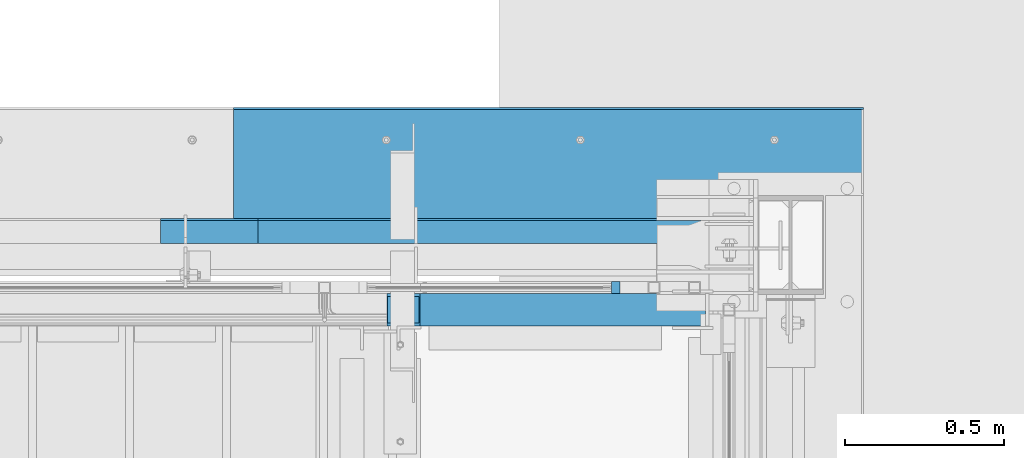
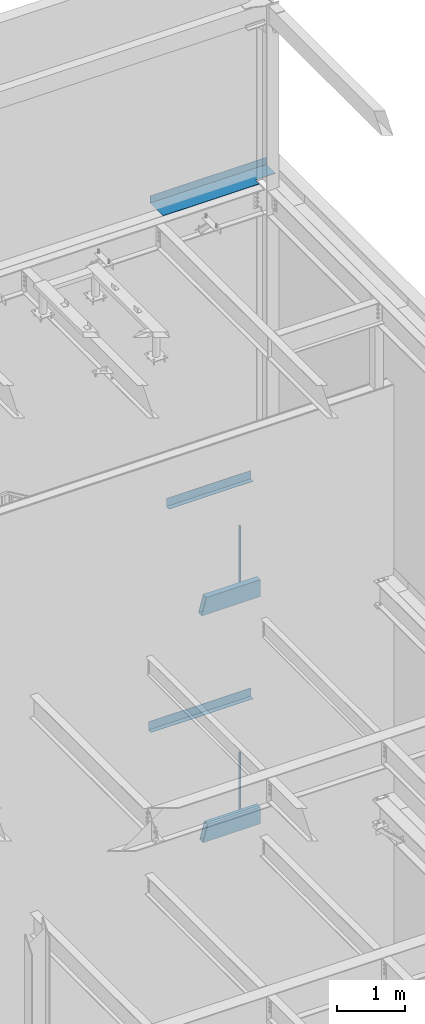
# One storey, part 800 of 1179: 5 beams, 2 members, 7 elements without a shape of their own.
"""IFC2X3 building model written with IfcOpenShell, lengths in millimetres."""

from ifc_helpers import new_model, si_unit, frame, origin_with_axes, place, context, subcontext, project, spatial, faceted_brep, material, type_object, element, aggregate, save


model = new_model("IFC2X3")

# Units and contexts
model_context = context("Model", 3, precision=1e-05, world=origin_with_axes())
body_context = subcontext(model_context, "Body", "Model", "MODEL_VIEW")
ifc_project = project(units=[si_unit("LENGTHUNIT", "METRE", prefix="MILLI"), si_unit("AREAUNIT", "SQUARE_METRE"), si_unit("VOLUMEUNIT", "CUBIC_METRE"), si_unit("MASSUNIT", "GRAM", prefix="KILO"), si_unit("TIMEUNIT", "SECOND"), si_unit("PLANEANGLEUNIT", "RADIAN"), si_unit("SOLIDANGLEUNIT", "STERADIAN"), si_unit("THERMODYNAMICTEMPERATUREUNIT", "DEGREE_CELSIUS"), si_unit("LUMINOUSINTENSITYUNIT", "LUMEN")], contexts=[model_context])

# Site, building, storey
site_placement = place(None, origin_with_axes())
site = spatial("IfcSite", under=ifc_project, at=site_placement, CompositionType="ELEMENT")
building_placement = place(site_placement, origin_with_axes())
building = spatial("IfcBuilding", under=site, at=building_placement, Name="Undefined", CompositionType="ELEMENT")
storey_placement = place(building_placement, origin_with_axes())
storey = spatial("IfcBuildingStorey", under=building, at=storey_placement, Name="Undefined", CompositionType="ELEMENT", Elevation=0.0)

# Assembly, member
assembly_1_placement = place(storey_placement, origin_with_axes())
assembly_1 = element("IfcElementAssembly", 1, at=assembly_1_placement, inside=storey, Name="GUARDRAIL", AssemblyPlace="NOTDEFINED", PredefinedType="RIGID_FRAME")
ifc_material_1 = material(Name="STEEL/A36")
member_type = type_object("IfcMemberType", PredefinedType="NOTDEFINED")
member_1_placement = place(assembly_1_placement, frame((23758.5250029074, 41065.4499993604, 1952.62499991228), z_axis=(0.0, -1.0, 0.0), x_axis=(0.0, 0.0, 1.0)))
member_1 = element("IfcMember", 2, at=member_1_placement, type_object=member_type, material=ifc_material_1, Name="POST", context=body_context, shape_type="Brep", body=[
    faceted_brep([(0.0, 12.7000000000007, -19.0500000000029), (0.0, 12.7000000000007, 19.0500000000029), (1212.8500000288, 12.7000000000007, 19.0500000000029), (1212.8500000288, 12.7000000000007, -19.0500000000029), (0.0, -12.7000000000007, 19.0500000000029), (1212.8500000288, -12.7000000000007, 19.0500000000029), (0.0, -12.7000000000007, -19.0500000000029), (1212.8500000288, -12.7000000000007, -19.0500000000029)], [[[0, 1, 2, 3]], [[1, 4, 5, 2]], [[4, 6, 7, 5]], [[6, 0, 3, 7]], [[5, 7, 3, 2]], [[6, 4, 1, 0]]]),
])
aggregate(assembly_1, [member_1])

assembly_2_placement = place(storey_placement, origin_with_axes())
assembly_2 = element("IfcElementAssembly", 3, at=assembly_2_placement, inside=storey, Name="GUARDRAIL", AssemblyPlace="NOTDEFINED", PredefinedType="RIGID_FRAME")
member_2_placement = place(assembly_2_placement, frame((23758.525002295, 41065.449999238, 6038.85000001208), z_axis=(0.0, -1.0, 0.0), x_axis=(0.0, 0.0, 1.0)))
member_2 = element("IfcMember", 4, at=member_2_placement, type_object=member_type, material=ifc_material_1, Name="POST", context=body_context, shape_type="Brep", body=[
    faceted_brep([(0.0, 12.7000000000007, -19.0500000000029), (0.0, 12.7000000000007, 19.0500000000029), (1200.14999994157, 12.7000000000007, 19.0500000000029), (1200.14999994157, 12.7000000000007, -19.0500000000029), (0.0, -12.7000000000007, 19.0500000000029), (1200.14999994157, -12.7000000000007, 19.0500000000029), (0.0, -12.7000000000007, -19.0500000000029), (1200.14999994157, -12.7000000000007, -19.0500000000029)], [[[0, 1, 2, 3]], [[1, 4, 5, 2]], [[4, 6, 7, 5]], [[6, 0, 3, 7]], [[5, 7, 3, 2]], [[6, 4, 1, 0]]]),
])
aggregate(assembly_2, [member_2])

# Assembly, beam
assembly_3_placement = place(storey_placement, origin_with_axes())
assembly_3 = element("IfcElementAssembly", 5, at=assembly_3_placement, inside=storey, Name="BEAM", AssemblyPlace="NOTDEFINED", PredefinedType="RIGID_FRAME")
beam_type_1 = type_object("IfcBeamType", PredefinedType="NOTDEFINED")
beam_1_placement = place(assembly_3_placement, frame((23198.9307500839, 41204.3562815049, 3933.82500614879), z_axis=(-1.0, 0.0, 0.0), x_axis=(0.0, 1.0, 0.0)))
beam_1 = element("IfcBeam", 6, at=beam_1_placement, type_object=beam_type_1, material=ifc_material_1, Name="BENT_PLATE", context=body_context, shape_type="Brep", body=[
    faceted_brep([(2.22644302994013e-09, -3.17500000000064, -869.950000000001), (-6.76664058119059e-10, -3.17500000000064, 869.950000000001), (-2.23371898755431e-09, 3.17499999999973, 869.950000000001), (6.69388100504875e-10, 3.17499999999973, -869.950000000001), (78.5812123482465, 3.17500001945837, 869.949999999844), (78.5812123494979, 3.17500001945837, -869.950000000154), (72.231211854174, -3.1749999821136, -869.950000000143), (72.2312118529226, -3.1749999821136, 869.949999999859), (78.5812004597101, -149.224999946321, 869.949999999702), (78.5812004625259, -149.224999944689, -869.950000000295), (72.2312004597043, -149.224999451009, 869.949999999717), (72.2312004625201, -149.224999449377, -869.950000000284)], [[[0, 1, 2, 3]], [[3, 2, 4, 5]], [[1, 0, 6, 7]], [[5, 4, 8, 9]], [[4, 2, 1, 7, 10, 8]], [[7, 6, 11, 10]], [[6, 0, 3, 5, 9, 11]], [[10, 11, 9, 8]]]),
])
aggregate(assembly_3, [beam_1])

assembly_4_placement = place(storey_placement, origin_with_axes())
assembly_4 = element("IfcElementAssembly", 7, at=assembly_4_placement, inside=storey, Name="BEAM", AssemblyPlace="NOTDEFINED", PredefinedType="RIGID_FRAME")
beam_2_placement = place(assembly_4_placement, frame((23351.3310000839, 41204.3562812314, 7845.42500614864), z_axis=(-1.0, 0.0, 0.0), x_axis=(0.0, 1.0, 0.0)))
beam_2 = element("IfcBeam", 8, at=beam_2_placement, type_object=beam_type_1, material=ifc_material_1, Name="BENT_PLATE", context=body_context, shape_type="Brep", body=[
    faceted_brep([(1.97178451344371e-09, -3.17500000000018, -716.7565), (-4.22005541622639e-10, -3.17500000000018, 716.7565), (-1.97906047105789e-09, 3.17500000000018, 716.7565), (4.14729584008455e-10, 3.17500000000018, -716.7565), (78.5812123420474, 3.17500001945882, 716.756499999847), (78.5812123430806, 3.17500001945882, -716.756500000156), (72.2312118477494, -3.17499998211406, -716.756500000141), (72.2312118467235, -3.17499998211406, 716.756499999858), (78.5812004536492, -149.224999952477, 716.756499999701), (78.581200455963, -149.224999951132, -716.756500000298), (72.2312004536507, -149.224999457165, 716.756499999716), (72.2312004559644, -149.224999455821, -716.756500000283)], [[[0, 1, 2, 3]], [[3, 2, 4, 5]], [[1, 0, 6, 7]], [[5, 4, 8, 9]], [[4, 2, 1, 7, 10, 8]], [[7, 6, 11, 10]], [[6, 0, 3, 5, 9, 11]], [[10, 11, 9, 8]]]),
])
aggregate(assembly_4, [beam_2])

assembly_5_placement = place(storey_placement, origin_with_axes())
assembly_5 = element("IfcElementAssembly", 9, at=assembly_5_placement, inside=storey, Name="BEAM", AssemblyPlace="NOTDEFINED", PredefinedType="RIGID_FRAME")
beam_type_2 = type_object("IfcBeamType", PredefinedType="NOTDEFINED")
beam_3_placement = place(assembly_5_placement, frame((23547.3874999922, 41244.8379999322, 13122.275), z_axis=(-1.0, 0.0, 0.0), x_axis=(0.0, 1.0, 0.0)))
beam_3 = element("IfcBeam", 10, at=beam_3_placement, type_object=beam_type_2, material=ifc_material_1, Name="BENT_PLATE", context=body_context, shape_type="Brep", body=[
    faceted_brep([(115.887000067814, -3.17499999999927, -644.525000007776), (115.887000067814, 3.17499999999927, -644.525000007776), (115.887000067814, 3.17499999999927, -989.012500000001), (115.887000067814, -3.17499999999927, -989.012500000001), (0.0, -3.17499999999927, -644.525000007776), (0.0, 3.17499999999927, -644.525000007776), (385.761999997871, 3.17499999999927, 989.0125), (0.0, 3.17499999999927, 989.0125), (0.0, -3.17499999999927, 989.0125), (379.411999997865, -3.17499999999927, 989.0125), (379.411999997865, -130.17500000214, 989.0125), (385.761999997871, -130.17500000214, 989.0125), (385.761999997871, 3.17499999999927, -989.0125), (385.761999997871, -130.17500000214, -989.0125), (379.411999997865, -130.17500000214, -989.0125), (379.411999997865, -3.17499999999927, -989.0125)], [[[0, 1, 2, 3]], [[4, 5, 1, 0]], [[6, 7, 8, 9, 10, 11]], [[12, 6, 11, 13]], [[10, 14, 13, 11]], [[9, 15, 14, 10]], [[12, 13, 14, 15, 3, 2]], [[7, 6, 12, 2, 1, 5]], [[8, 7, 5, 4]], [[15, 9, 8, 4, 0, 3]]]),
])
aggregate(assembly_5, [beam_3])

assembly_6_placement = place(storey_placement, origin_with_axes())
assembly_6 = element("IfcElementAssembly", 11, at=assembly_6_placement, inside=storey, Name="STAIR", AssemblyPlace="NOTDEFINED", PredefinedType="RIGID_FRAME")
ifc_material_2 = material()
beam_type_3 = type_object("IfcBeamType", Name="HSS12X4X3/8", PredefinedType="NOTDEFINED")
beam_4_placement = place(assembly_6_placement, frame((24117.3000000109, 40995.6, 6089.65000001257), z_axis=(0.0, 0.0, 1.0), x_axis=(-1.0, 0.0, 0.0)))
beam_4 = element("IfcBeam", 12, at=beam_4_placement, type_object=beam_type_3, material=ifc_material_2, Name="STAIR", ObjectType="HSS12X4X3/8", context=body_context, shape_type="Brep", body=[
    faceted_brep([(76.2000000108455, 41.2750000000015, -142.875), (76.2000000108455, -41.2750000000015, -142.875), (1075.35333158851, -41.2750000000015, -142.875), (1075.35333158851, 41.2750000000015, -142.875), (76.2000000108455, -41.2750000000015, 142.875), (998.1010644749, -41.2750000000015, 142.875), (76.2000000108455, 41.2750000000015, 142.875), (998.1010644749, 41.2750000000015, 142.875), (76.2000000108455, 50.8000000000029, -152.4), (76.2000000108455, 50.8000000000029, 152.4), (995.525988904446, 50.8000000000029, 152.4), (1077.92840715896, 50.8000000000029, -152.4), (76.2000000108455, -50.8000000000029, 152.4), (995.525988904446, -50.8000000000029, 152.4), (76.2000000108455, -50.8000000000029, -152.4), (1077.92840715896, -50.8000000000029, -152.4)], [[[0, 1, 2, 3]], [[1, 4, 5, 2]], [[4, 6, 7, 5]], [[6, 0, 3, 7]], [[8, 9, 10, 11]], [[9, 12, 13, 10]], [[12, 14, 15, 13]], [[14, 8, 11, 15]], [[13, 15, 11, 10], [5, 7, 3, 2]], [[14, 12, 9, 8], [6, 4, 1, 0]]]),
])
aggregate(assembly_6, [beam_4])

assembly_7_placement = place(storey_placement, origin_with_axes())
assembly_7 = element("IfcElementAssembly", 13, at=assembly_7_placement, inside=storey, Name="STAIR", AssemblyPlace="NOTDEFINED", PredefinedType="RIGID_FRAME")
beam_5_placement = place(assembly_7_placement, frame((24117.300000324, 40995.5999999994, 2003.42500000014), z_axis=(0.0, 0.0, 1.0), x_axis=(-1.0, 0.0, 0.0)))
beam_5 = element("IfcBeam", 14, at=beam_5_placement, type_object=beam_type_3, material=ifc_material_2, Name="STAIR", ObjectType="HSS12X4X3/8", context=body_context, shape_type="Brep", body=[
    faceted_brep([(76.2000000108455, 41.2750000000015, -142.875), (76.2000000108455, -41.2750000000015, -142.875), (1053.27551519705, -41.2750000000015, -142.875), (1053.27551519705, 41.2750000000015, -142.875), (76.2000000108455, -41.2750000000015, 142.875), (976.52046313975, -41.2750000000015, 142.875), (76.2000000108455, 41.2750000000015, 142.875), (976.52046313975, 41.2750000000015, 142.875), (76.2000000108455, 50.8000000000029, -152.4), (76.2000000108455, 50.8000000000029, 152.4), (973.961961404504, 50.8000000000029, 152.4), (1055.83401693229, 50.8000000000029, -152.4), (76.2000000108455, -50.8000000000029, 152.4), (973.961961404504, -50.8000000000029, 152.4), (76.2000000108455, -50.8000000000029, -152.4), (1055.83401693229, -50.8000000000029, -152.4)], [[[0, 1, 2, 3]], [[1, 4, 5, 2]], [[4, 6, 7, 5]], [[6, 0, 3, 7]], [[8, 9, 10, 11]], [[9, 12, 13, 10]], [[12, 14, 15, 13]], [[14, 8, 11, 15]], [[13, 15, 11, 10], [5, 7, 3, 2]], [[14, 12, 9, 8], [6, 4, 1, 0]]]),
])
aggregate(assembly_7, [beam_5])

save(model, "model.ifc")
